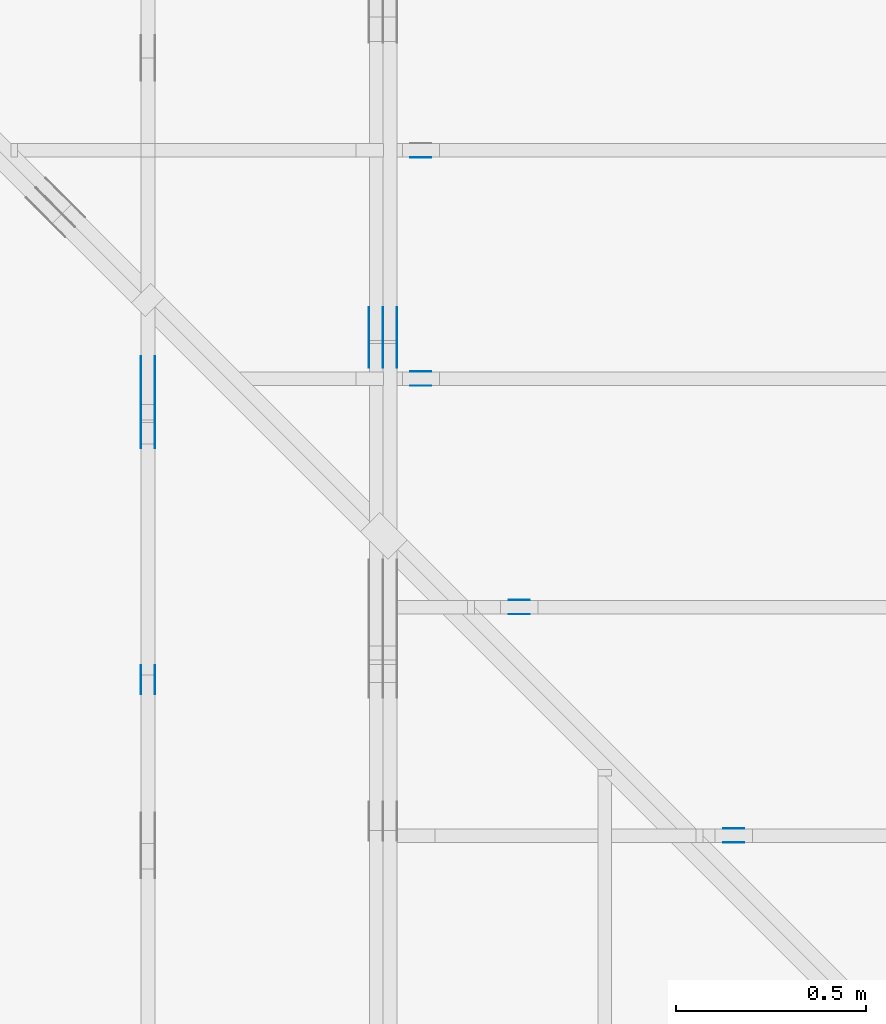
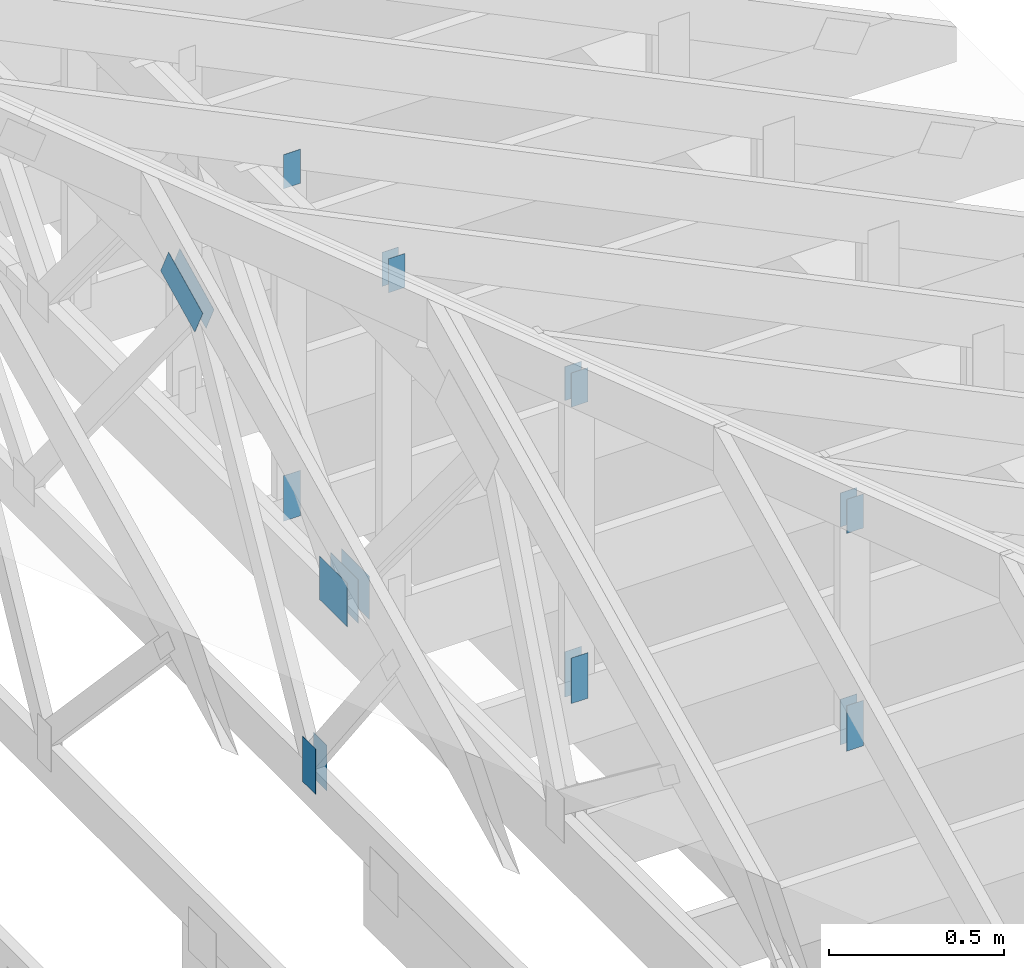
# One storey, part 116 of 159: 20 plates, 6 elements without a shape of their own.
"""IFC2X3 building model written with IfcOpenShell, lengths in millimetres."""

from ifc_helpers import new_model, si_unit, frame, origin, origin_with_axes, origin_2d, place, context, project, spatial, faceted_brep, element, aggregate, save


model = new_model("IFC2X3")

# Units and contexts
model_context = context("Model", 3, precision=1e-05, world=origin())
plan_context = context("Plan", 2, precision=1e-05, world=origin_2d())
ifc_project = project(units=[si_unit("LENGTHUNIT", "METRE", prefix="MILLI"), si_unit("AREAUNIT", "SQUARE_METRE"), si_unit("VOLUMEUNIT", "CUBIC_METRE"), si_unit("SOLIDANGLEUNIT", "STERADIAN"), si_unit("PLANEANGLEUNIT", "RADIAN"), si_unit("MASSUNIT", "GRAM"), si_unit("TIMEUNIT", "SECOND"), si_unit("THERMODYNAMICTEMPERATUREUNIT", "DEGREE_CELSIUS"), si_unit("LUMINOUSINTENSITYUNIT", "LUMEN")], contexts=[model_context, plan_context])

# Site, building, storey
site_placement = place(None, origin_with_axes())
site = spatial("IfcSite", under=ifc_project, at=site_placement, CompositionType="ELEMENT")
building_placement = place(site_placement, origin_with_axes())
building = spatial("IfcBuilding", under=site, at=building_placement, Name="Plan 1", CompositionType="ELEMENT")
storey_placement = place(building_placement, origin_with_axes())
storey = spatial("IfcBuildingStorey", under=building, at=storey_placement, Name="Etasje 1", CompositionType="ELEMENT", Elevation=0.0)

# Assembly, plates
assembly_1_placement = place(storey_placement, frame((18074.541652722903, -699.9989301294845, 4.408582873760558e-15), z_axis=(-1.0, 1.836909530733566e-16, 6.123031769111886e-17), x_axis=(-1.836909530733566e-16, -1.0, 0.0)))
assembly_1 = element("IfcElementAssembly", 1, at=assembly_1_placement, inside=storey, Name="V5 (30)", AssemblyPlace="FACTORY", PredefinedType="TRUSS")
plate_1_placement = place(assembly_1_placement, frame((-3428.636962890625, 299.0, 0.0), z_axis=(0.0, 0.0, 1.0), x_axis=(-1.0, 1.2246063538223773e-16, 0.0)))
plate_1 = element("IfcPlate", 2, at=plate_1_placement, Name="GNT100S 152x159", context=model_context, shape_type="Brep", body=[
    faceted_brep([(159.0, 152.00000000000003, 1.0), (0.0, 152.00000000000003, 1.0), (0.0, 0.0, 1.0), (159.0, 0.0, 1.0), (0.0, 152.00000000000003, 0.0), (159.0, 152.00000000000003, 1.9471241025775798e-14), (159.0, 5.684341886080802e-14, 1.9471241025775798e-14), (0.0, 5.684341886080802e-14, 0.0), (159.00003704238225, 6.529141447438163e-13, 5.2688872337669284e-30), (159.00003704238225, 6.529753750615074e-13, 1.0), (3.704238224599976e-05, 6.821822366001711e-13, 1.0), (3.704238224599976e-05, 6.8212100628248e-13, 1.227497416848817e-36), (159.00003704238225, 152.0000000000007, 0.0), (159.00003704238225, 152.0000000000007, 1.0), (159.00003704238225, 7.389644451905042e-13, 1.0), (159.00003704238225, 7.389644451905042e-13, 0.0), (3.704238224599976e-05, 152.0000000000007, 0.0), (3.704238224599976e-05, 152.0000000000007, 1.0), (159.00003704238225, 152.0000000000007, 1.0), (159.00003704238225, 152.0000000000007, 0.0), (3.704238224599976e-05, 6.821210263296962e-13, 0.0), (3.704238224606099e-05, 6.821210263296962e-13, 1.0), (3.704238226467501e-05, 152.0000000000007, 1.0), (3.704238226461378e-05, 152.0000000000007, -1.1397420192804459e-30)], [[[0, 1, 2, 3]], [[4, 5, 6, 7]], [[8, 9, 10, 11]], [[12, 13, 14, 15]], [[16, 17, 18, 19]], [[20, 21, 22, 23]]]),
])
plate_2_placement = place(assembly_1_placement, frame((-3428.636962890625, 299.0, -37.0), z_axis=(0.0, 0.0, 1.0), x_axis=(-1.0, 1.2246063538223773e-16, 0.0)))
plate_2 = element("IfcPlate", 3, at=plate_2_placement, Name="GNT100S 152x159", context=model_context, shape_type="Brep", body=[
    faceted_brep([(159.0, 152.00000000000003, 1.0), (0.0, 152.00000000000003, 1.0), (0.0, 0.0, 1.0), (159.0, 0.0, 1.0), (0.0, 152.00000000000003, 0.0), (159.0, 152.00000000000003, 1.9471241025775798e-14), (159.0, 5.684341886080802e-14, 1.9471241025775798e-14), (0.0, 5.684341886080802e-14, 0.0), (159.00003704238225, 6.529141447438163e-13, 5.2688872337669284e-30), (159.00003704238225, 6.529753750615074e-13, 1.0), (3.704238224599976e-05, 6.821822366001711e-13, 1.0), (3.704238224599976e-05, 6.8212100628248e-13, 1.227497416848817e-36), (159.00003704238225, 152.0000000000007, 0.0), (159.00003704238225, 152.0000000000007, 1.0), (159.00003704238225, 7.389644451905042e-13, 1.0), (159.00003704238225, 7.389644451905042e-13, 0.0), (3.704238224599976e-05, 152.0000000000007, 0.0), (3.704238224599976e-05, 152.0000000000007, 1.0), (159.00003704238225, 152.0000000000007, 1.0), (159.00003704238225, 152.0000000000007, 0.0), (3.704238224599976e-05, 6.821210263296962e-13, 0.0), (3.704238224606099e-05, 6.821210263296962e-13, 1.0), (3.704238226467501e-05, 152.0000000000007, 1.0), (3.704238226461378e-05, 152.0000000000007, -1.1397420192804459e-30)], [[[0, 1, 2, 3]], [[4, 5, 6, 7]], [[8, 9, 10, 11]], [[12, 13, 14, 15]], [[16, 17, 18, 19]], [[20, 21, 22, 23]]]),
])
plate_3_placement = place(assembly_1_placement, frame((-3428.636962890625, 299.0, -36.0), z_axis=(0.0, 0.0, 1.0), x_axis=(-1.0, 1.2246063538223773e-16, 0.0)))
plate_3 = element("IfcPlate", 4, at=plate_3_placement, Name="GNT100S 152x159", context=model_context, shape_type="Brep", body=[
    faceted_brep([(159.0, 152.00000000000003, 1.0), (0.0, 152.00000000000003, 1.0), (0.0, 0.0, 1.0), (159.0, 0.0, 1.0), (0.0, 152.00000000000003, 0.0), (159.0, 152.00000000000003, 1.9471241025775798e-14), (159.0, 5.684341886080802e-14, 1.9471241025775798e-14), (0.0, 5.684341886080802e-14, 0.0), (159.00003704238225, 6.529141447438163e-13, 5.2688872337669284e-30), (159.00003704238225, 6.529753750615074e-13, 1.0), (3.704238224599976e-05, 6.821822366001711e-13, 1.0), (3.704238224599976e-05, 6.8212100628248e-13, 1.227497416848817e-36), (159.00003704238225, 152.0000000000007, 0.0), (159.00003704238225, 152.0000000000007, 1.0), (159.00003704238225, 7.389644451905042e-13, 1.0), (159.00003704238225, 7.389644451905042e-13, 0.0), (3.704238224599976e-05, 152.0000000000007, 0.0), (3.704238224599976e-05, 152.0000000000007, 1.0), (159.00003704238225, 152.0000000000007, 1.0), (159.00003704238225, 152.0000000000007, 0.0), (3.704238224599976e-05, 6.821210263296962e-13, 0.0), (3.704238224606099e-05, 6.821210263296962e-13, 1.0), (3.704238226467501e-05, 152.0000000000007, 1.0), (3.704238226461378e-05, 152.0000000000007, -1.1397420192804459e-30)], [[[0, 1, 2, 3]], [[4, 5, 6, 7]], [[8, 9, 10, 11]], [[12, 13, 14, 15]], [[16, 17, 18, 19]], [[20, 21, 22, 23]]]),
])
plate_4_placement = place(assembly_1_placement, frame((-3428.636962890625, 299.0, -73.0), z_axis=(0.0, 0.0, 1.0), x_axis=(-1.0, 1.2246063538223773e-16, 0.0)))
plate_4 = element("IfcPlate", 5, at=plate_4_placement, Name="GNT100S 152x159", context=model_context, shape_type="Brep", body=[
    faceted_brep([(159.0, 152.00000000000003, 1.0), (0.0, 152.00000000000003, 1.0), (0.0, 0.0, 1.0), (159.0, 0.0, 1.0), (0.0, 152.00000000000003, 0.0), (159.0, 152.00000000000003, 1.9471241025775798e-14), (159.0, 5.684341886080802e-14, 1.9471241025775798e-14), (0.0, 5.684341886080802e-14, 0.0), (159.00003704238225, 6.529141447438163e-13, 5.2688872337669284e-30), (159.00003704238225, 6.529753750615074e-13, 1.0), (3.704238224599976e-05, 6.821822366001711e-13, 1.0), (3.704238224599976e-05, 6.8212100628248e-13, 1.227497416848817e-36), (159.00003704238225, 152.0000000000007, 0.0), (159.00003704238225, 152.0000000000007, 1.0), (159.00003704238225, 7.389644451905042e-13, 1.0), (159.00003704238225, 7.389644451905042e-13, 0.0), (3.704238224599976e-05, 152.0000000000007, 0.0), (3.704238224599976e-05, 152.0000000000007, 1.0), (159.00003704238225, 152.0000000000007, 1.0), (159.00003704238225, 152.0000000000007, 0.0), (3.704238224599976e-05, 6.821210263296962e-13, 0.0), (3.704238224606099e-05, 6.821210263296962e-13, 1.0), (3.704238226467501e-05, 152.0000000000007, 1.0), (3.704238226461378e-05, 152.0000000000007, -1.1397420192804459e-30)], [[[0, 1, 2, 3]], [[4, 5, 6, 7]], [[8, 9, 10, 11]], [[12, 13, 14, 15]], [[16, 17, 18, 19]], [[20, 21, 22, 23]]]),
])
aggregate(assembly_1, [plate_1, plate_2, plate_3, plate_4])

assembly_2_placement = place(storey_placement, frame((17475.02226140475, -699.9989301294827, 1.1021457184401395e-15), z_axis=(-1.0, 1.836909530733566e-16, 6.123031769111886e-17), x_axis=(-1.836909530733566e-16, -1.0, 0.0)))
assembly_2 = element("IfcElementAssembly", 6, at=assembly_2_placement, inside=storey, Name="V6 (31)", AssemblyPlace="FACTORY", PredefinedType="TRUSS")
plate_5_placement = place(assembly_2_placement, frame((-3217.9081733835806, 1580.4437865648827, 0.0), z_axis=(0.0, 0.0, 1.0), x_axis=(-0.898794046299167, 0.4383711467890773, 0.0)))
plate_5 = element("IfcPlate", 7, at=plate_5_placement, Name="GNT100S 103x218", context=model_context, shape_type="Brep", body=[
    faceted_brep([(218.00002818462735, 103.00013551740335, 1.0), (9.564507581671933e-05, 103.00013551740335, 1.0), (0.0, 6.784529296055553e-05, 1.0), (217.99993253955154, 6.784529296055553e-05, 1.0), (9.564507581671933e-05, 103.00013551740335, 1.1712756755697749e-20), (218.00002818462735, 103.00013551740335, 2.66964219648352e-14), (217.99993253955154, 0.0, 2.6696410252078444e-14), (0.0, 0.0, 0.0), (218.0000093475328, 8.409083143848917e-05, 2.4519450465496925e-30), (218.0000093475328, 8.40908314385504e-05, 1.0), (9.347532795800362e-06, 8.409083147859503e-05, 1.0), (9.347532795800362e-06, 8.40908314785338e-05, 0.0), (218.0000093475328, 103.00008409083148, -2.8398992587956425e-29), (218.0000093475328, 103.00008409083148, 1.0), (218.0000093475328, 8.40908314785338e-05, 1.0), (218.0000093475328, 8.40908314785338e-05, 0.0), (9.347533250547713e-06, 103.00008409083148, 0.0), (9.347533250547713e-06, 103.00008409083148, 1.0), (218.00000934753325, 103.00008409083146, 1.0), (218.00000934753325, 103.00008409083146, -7.888609052210118e-31), (9.347532795800375e-06, 8.40908314785338e-05, -7.52316384526264e-37), (9.347532795861606e-06, 8.40908314785338e-05, 1.0), (9.347533265886937e-06, 103.00008409083148, 1.0), (9.347533265825707e-06, 103.00008409083148, -9.35476365938057e-31)], [[[0, 1, 2, 3]], [[4, 5, 6, 7]], [[8, 9, 10, 11]], [[12, 13, 14, 15]], [[16, 17, 18, 19]], [[20, 21, 22, 23]]]),
])
plate_6_placement = place(assembly_2_placement, frame((-3217.9081733835806, 1580.4437865648827, -37.0), z_axis=(0.0, 0.0, 1.0), x_axis=(-0.898794046299167, 0.4383711467890773, 0.0)))
plate_6 = element("IfcPlate", 8, at=plate_6_placement, Name="GNT100S 103x218", context=model_context, shape_type="Brep", body=[
    faceted_brep([(218.00002818462735, 103.00013551740335, 1.0), (9.564507581671933e-05, 103.00013551740335, 1.0), (0.0, 6.784529296055553e-05, 1.0), (217.99993253955154, 6.784529296055553e-05, 1.0), (9.564507581671933e-05, 103.00013551740335, 1.1712756755697749e-20), (218.00002818462735, 103.00013551740335, 2.66964219648352e-14), (217.99993253955154, 0.0, 2.6696410252078444e-14), (0.0, 0.0, 0.0), (218.0000093475328, 8.409083143848917e-05, 2.4519450465496925e-30), (218.0000093475328, 8.40908314385504e-05, 1.0), (9.347532795800362e-06, 8.409083147859503e-05, 1.0), (9.347532795800362e-06, 8.40908314785338e-05, 0.0), (218.0000093475328, 103.00008409083148, -2.8398992587956425e-29), (218.0000093475328, 103.00008409083148, 1.0), (218.0000093475328, 8.40908314785338e-05, 1.0), (218.0000093475328, 8.40908314785338e-05, 0.0), (9.347533250547713e-06, 103.00008409083148, 0.0), (9.347533250547713e-06, 103.00008409083148, 1.0), (218.00000934753325, 103.00008409083146, 1.0), (218.00000934753325, 103.00008409083146, -7.888609052210118e-31), (9.347532795800375e-06, 8.40908314785338e-05, -7.52316384526264e-37), (9.347532795861606e-06, 8.40908314785338e-05, 1.0), (9.347533265886937e-06, 103.00008409083148, 1.0), (9.347533265825707e-06, 103.00008409083148, -9.35476365938057e-31)], [[[0, 1, 2, 3]], [[4, 5, 6, 7]], [[8, 9, 10, 11]], [[12, 13, 14, 15]], [[16, 17, 18, 19]], [[20, 21, 22, 23]]]),
])
plate_7_placement = place(assembly_2_placement, frame((-2571.392481149558, 291.4999999999981, 0.0), z_axis=(0.0, 0.0, 1.0), x_axis=(6.123031769111886e-17, 1.0, 0.0)))
plate_7 = element("IfcPlate", 9, at=plate_7_placement, Name="GNT100S 76x159", context=model_context, shape_type="Brep", body=[
    faceted_brep([(159.00000000000188, 76.00009697544192, 1.0), (1.8758328224066645e-12, 76.00009697544192, 1.0), (1.8758328224066645e-12, 9.697544192022178e-05, 1.0), (159.00000000000188, 9.697544192022178e-05, 1.0), (1.8758328224066645e-12, 76.00009697544192, 2.2971567930277643e-28), (159.00000000000188, 76.00009697544192, 1.947124102577603e-14), (159.00000000000188, 9.697544192022178e-05, 1.947124102577603e-14), (1.8758328224066645e-12, 9.697544192022178e-05, 2.2971567930277643e-28), (159.0, -2.92068615386637e-14, 1.788345410772899e-30), (159.0, -2.914563122097258e-14, 1.0), (1.1247455413666031e-32, 6.123031769111886e-17, 1.0), (0.0, 0.0, 0.0), (159.0, 76.0, 0.0), (159.0, 76.0, 1.0), (159.0, 0.0, 1.0), (159.0, 0.0, 0.0), (0.0, 76.0, 0.0), (-3.7491518045553436e-33, 76.0, 1.0), (159.0, 75.99999999999999, 1.0), (159.0, 75.99999999999999, -7.888609052210118e-31), (0.0, 0.0, 0.0), (6.123031769111886e-17, -7.498303609110687e-33, 1.0), (9.368238606741186e-15, 76.0, 1.0), (9.307008289050067e-15, 76.0, -5.698710742924122e-31)], [[[0, 1, 2, 3]], [[4, 5, 6, 7]], [[8, 9, 10, 11]], [[12, 13, 14, 15]], [[16, 17, 18, 19]], [[20, 21, 22, 23]]]),
])
plate_8_placement = place(assembly_2_placement, frame((-2571.392481149558, 291.4999999999981, -37.0), z_axis=(0.0, 0.0, 1.0), x_axis=(6.123031769111886e-17, 1.0, 0.0)))
plate_8 = element("IfcPlate", 10, at=plate_8_placement, Name="GNT100S 76x159", context=model_context, shape_type="Brep", body=[
    faceted_brep([(159.00000000000188, 76.00009697544192, 1.0), (1.8758328224066645e-12, 76.00009697544192, 1.0), (1.8758328224066645e-12, 9.697544192022178e-05, 1.0), (159.00000000000188, 9.697544192022178e-05, 1.0), (1.8758328224066645e-12, 76.00009697544192, 2.2971567930277643e-28), (159.00000000000188, 76.00009697544192, 1.947124102577603e-14), (159.00000000000188, 9.697544192022178e-05, 1.947124102577603e-14), (1.8758328224066645e-12, 9.697544192022178e-05, 2.2971567930277643e-28), (159.0, -2.92068615386637e-14, 1.788345410772899e-30), (159.0, -2.914563122097258e-14, 1.0), (1.1247455413666031e-32, 6.123031769111886e-17, 1.0), (0.0, 0.0, 0.0), (159.0, 76.0, 0.0), (159.0, 76.0, 1.0), (159.0, 0.0, 1.0), (159.0, 0.0, 0.0), (0.0, 76.0, 0.0), (-3.7491518045553436e-33, 76.0, 1.0), (159.0, 75.99999999999999, 1.0), (159.0, 75.99999999999999, -7.888609052210118e-31), (0.0, 0.0, 0.0), (6.123031769111886e-17, -7.498303609110687e-33, 1.0), (9.368238606741186e-15, 76.0, 1.0), (9.307008289050067e-15, 76.0, -5.698710742924122e-31)], [[[0, 1, 2, 3]], [[4, 5, 6, 7]], [[8, 9, 10, 11]], [[12, 13, 14, 15]], [[16, 17, 18, 19]], [[20, 21, 22, 23]]]),
])
aggregate(assembly_2, [plate_5, plate_6, plate_7, plate_8])

assembly_3_placement = place(storey_placement, frame((21100.012663101486, 3318.0074014212582, 1.1021457184401395e-15), z_axis=(1.2246063538223773e-16, 1.0, 6.123031769111886e-17), x_axis=(-1.0, 1.2246063538223773e-16, 0.0)))
assembly_3 = element("IfcElementAssembly", 11, at=assembly_3_placement, inside=storey, Name="S15 (41)", AssemblyPlace="FACTORY", PredefinedType="TRUSS")
plate_9_placement = place(assembly_3_placement, frame((2862.490401698563, 1424.37744140625, -37.0), z_axis=(0.0, 0.0, 1.0), x_axis=(6.123031769111886e-17, -1.0, 0.0)))
plate_9 = element("IfcPlate", 12, at=plate_9_placement, Name="GNT100S 55x119", context=model_context, shape_type="Brep", body=[
    faceted_brep([(119.0, 55.00007681706211, 1.0), (0.0, 55.00007681706211, 1.0), (0.0, 7.681706210860284e-05, 1.0), (119.0, 7.681706210860284e-05, 1.0), (0.0, 55.00007681706211, 0.0), (119.0, 55.00007681706211, 1.457281561048629e-14), (119.0, 7.681706210860284e-05, 1.457281561048629e-14), (0.0, 7.681706210860284e-05, 0.0), (119.00002904577786, -2.1859228751176052e-14, 1.3384475209173491e-30), (119.00002904577786, -2.1797998433484933e-14, 1.0), (2.904577786466689e-05, 6.122498224450015e-17, 1.0), (2.904577786466689e-05, -5.335446618717665e-21, 3.2669109148808856e-37), (119.00002904577786, 55.0, 0.0), (119.00002904577786, 55.0, 1.0), (119.00002904577786, 0.0, 1.0), (119.00002904577786, 0.0, 0.0), (2.904577786466689e-05, 55.0, 0.0), (2.904577786466689e-05, 55.0, 1.0), (119.00002904577786, 54.99999999999999, 1.0), (119.00002904577786, 54.99999999999999, -3.944304526105059e-31), (2.904577786466689e-05, 0.0, 0.0), (2.904577786472812e-05, -7.498303609110687e-33, 1.0), (2.9045777871463454e-05, 55.0, 1.0), (2.9045777871402223e-05, 55.0, -4.124066764605687e-31)], [[[0, 1, 2, 3]], [[4, 5, 6, 7]], [[8, 9, 10, 11]], [[12, 13, 14, 15]], [[16, 17, 18, 19]], [[20, 21, 22, 23]]]),
])
plate_10_placement = place(assembly_3_placement, frame((2917.490478515625, 143.5, -37.0), z_axis=(0.0, 0.0, 1.0), x_axis=(6.123031769111886e-17, 1.0, 0.0)))
plate_10 = element("IfcPlate", 13, at=plate_10_placement, Name="GNT100S 55x159", context=model_context, shape_type="Brep", body=[
    faceted_brep([(159.0, 55.0, 1.0), (0.0, 55.0, 1.0), (0.0, 0.0, 1.0), (159.0, 0.0, 1.0), (0.0, 55.0, 0.0), (159.0, 55.0, 1.9471241025775798e-14), (159.0, 0.0, 1.9471241025775798e-14), (0.0, 0.0, 0.0), (159.0, 7.681706480788008e-05, 1.788345571668688e-30), (159.0, 7.681706480794131e-05, 1.0), (1.1247455413666031e-32, 7.681706483714818e-05, 1.0), (0.0, 7.681706483708695e-05, 0.0), (159.0, 55.00007681706484, 0.0), (159.0, 55.00007681706484, 1.0), (159.0, 7.681706483708695e-05, 1.0), (159.0, 7.681706483708695e-05, 0.0), (-2.4308653429145085e-63, 55.00007681706484, 0.0), (-3.7491518045553436e-33, 55.00007681706484, 1.0), (159.0, 55.00007681706483, 1.0), (159.0, 55.00007681706483, -7.888609052210118e-31), (9.407066568148219e-21, 7.681706483708695e-05, -5.759976745092187e-37), (6.123972475768701e-17, 7.681706483708695e-05, 1.0), (6.796574670780762e-15, 55.00007681706484, 1.0), (6.7353443530896435e-15, 55.00007681706484, -4.124072744987623e-31)], [[[0, 1, 2, 3]], [[4, 5, 6, 7]], [[8, 9, 10, 11]], [[12, 13, 14, 15]], [[16, 17, 18, 19]], [[20, 21, 22, 23]]]),
])
aggregate(assembly_3, [plate_9, plate_10])

assembly_4_placement = place(storey_placement, frame((21100.012663101486, 1518.0074014212582, 1.1021457184401395e-15), z_axis=(1.2246063538223773e-16, 1.0, 6.123031769111886e-17), x_axis=(-1.0, 1.2246063538223773e-16, 0.0)))
assembly_4 = element("IfcElementAssembly", 14, at=assembly_4_placement, inside=storey, Name="S18 (40)", AssemblyPlace="FACTORY", PredefinedType="TRUSS")
plate_11_placement = place(assembly_4_placement, frame((2040.5946044921875, 1023.5120849609375, 0.0), z_axis=(0.0, 0.0, 1.0), x_axis=(6.123031769111886e-17, -1.0, 0.0)))
plate_11 = element("IfcPlate", 15, at=plate_11_placement, Name="GNT100S 55x119", context=model_context, shape_type="Brep", body=[
    faceted_brep([(119.0, 55.0001220703125, 1.0), (0.0, 55.0001220703125, 1.0), (0.0, 0.0, 1.0), (119.0, 0.0, 1.0), (0.0, 55.0001220703125, 0.0), (119.0, 55.0001220703125, 1.457281561048629e-14), (119.0, 0.0, 1.457281561048629e-14), (0.0, 0.0, 0.0), (119.0000183720665, 3.881499376435889e-05, 1.3384475843434453e-30), (119.0000183720665, 3.881499376442012e-05, 1.0), (1.837206650634471e-05, 3.881499378627934e-05, 1.0), (1.837206650634471e-05, 3.881499378621811e-05, 3.76158192263132e-37), (119.0000183720665, 55.000038814993786, 0.0), (119.0000183720665, 55.000038814993786, 1.0), (119.0000183720665, 3.881499378621811e-05, 1.0), (119.0000183720665, 3.881499378621811e-05, 0.0), (1.837206650634471e-05, 55.000038814993786, 0.0), (1.837206650634471e-05, 55.000038814993786, 1.0), (119.0000183720665, 55.00003881499378, 1.0), (119.0000183720665, 55.00003881499378, -3.944304526105059e-31), (1.8372066506344712e-05, 3.881499378621811e-05, -3.76158192263132e-37), (1.8372066506405942e-05, 3.881499378621811e-05, 1.0), (1.8372066513141277e-05, 55.000038814993786, 1.0), (1.8372066513080047e-05, 55.000038814993786, -4.12407052618761e-31)], [[[0, 1, 2, 3]], [[4, 5, 6, 7]], [[8, 9, 10, 11]], [[12, 13, 14, 15]], [[16, 17, 18, 19]], [[20, 21, 22, 23]]]),
])
plate_12_placement = place(assembly_4_placement, frame((2040.5946044921875, 1023.5120849609375, -37.0), z_axis=(0.0, 0.0, 1.0), x_axis=(6.123031769111886e-17, -1.0, 0.0)))
plate_12 = element("IfcPlate", 16, at=plate_12_placement, Name="GNT100S 55x119", context=model_context, shape_type="Brep", body=[
    faceted_brep([(119.0, 55.0001220703125, 1.0), (0.0, 55.0001220703125, 1.0), (0.0, 0.0, 1.0), (119.0, 0.0, 1.0), (0.0, 55.0001220703125, 0.0), (119.0, 55.0001220703125, 1.457281561048629e-14), (119.0, 0.0, 1.457281561048629e-14), (0.0, 0.0, 0.0), (119.0000183720665, 3.881499376435889e-05, 1.3384475843434453e-30), (119.0000183720665, 3.881499376442012e-05, 1.0), (1.837206650634471e-05, 3.881499378627934e-05, 1.0), (1.837206650634471e-05, 3.881499378621811e-05, 3.76158192263132e-37), (119.0000183720665, 55.000038814993786, 0.0), (119.0000183720665, 55.000038814993786, 1.0), (119.0000183720665, 3.881499378621811e-05, 1.0), (119.0000183720665, 3.881499378621811e-05, 0.0), (1.837206650634471e-05, 55.000038814993786, 0.0), (1.837206650634471e-05, 55.000038814993786, 1.0), (119.0000183720665, 55.00003881499378, 1.0), (119.0000183720665, 55.00003881499378, -3.944304526105059e-31), (1.8372066506344712e-05, 3.881499378621811e-05, -3.76158192263132e-37), (1.8372066506405942e-05, 3.881499378621811e-05, 1.0), (1.8372066513141277e-05, 55.000038814993786, 1.0), (1.8372066513080047e-05, 55.000038814993786, -4.12407052618761e-31)], [[[0, 1, 2, 3]], [[4, 5, 6, 7]], [[8, 9, 10, 11]], [[12, 13, 14, 15]], [[16, 17, 18, 19]], [[20, 21, 22, 23]]]),
])
plate_13_placement = place(assembly_4_placement, frame((2095.5947265625, 143.49999999999997, 0.0), z_axis=(0.0, 0.0, 1.0), x_axis=(6.123031769111886e-17, 1.0, 0.0)))
plate_13 = element("IfcPlate", 17, at=plate_13_placement, Name="GNT100S 55x159", context=model_context, shape_type="Brep", body=[
    faceted_brep([(159.0, 55.0001220703125, 1.0), (0.0, 55.0001220703125, 1.0), (2.842170943040401e-14, 0.0, 1.0), (159.0, 0.0, 1.0), (0.0, 55.0001220703125, 0.0), (159.0, 55.0001220703125, 1.9471241025775798e-14), (159.0, 0.0, 1.9471241025775798e-14), (2.842170943040401e-14, 0.0, 3.4805405954966126e-30), (159.0, 8.325534869790019e-05, 1.788345571668688e-30), (159.0, 8.325534869796142e-05, 1.0), (2.842170943040401e-14, 8.325534872716828e-05, 1.0), (2.842170943040401e-14, 8.325534872710705e-05, 0.0), (159.0, 55.00008325534873, 0.0), (159.0, 55.00008325534873, 1.0), (159.0, 8.325534872710705e-05, 1.0), (159.0, 8.325534872710705e-05, 0.0), (0.0, 55.00008325534873, 0.0), (-3.7491518045553436e-33, 55.00008325534873, 1.0), (159.0, 55.00008325534872, 1.0), (159.0, 55.00008325534872, -7.888609052210118e-31), (2.8421725676001787e-14, 8.325534872710705e-05, -9.947231130626802e-37), (2.8482955993692906e-14, 8.325534872710705e-05, 1.0), (1.0793384397962537e-14, 55.00008325534873, 1.0), (1.0732154080271418e-14, 55.00008325534873, -6.571332038450564e-31)], [[[0, 1, 2, 3]], [[4, 5, 6, 7]], [[8, 9, 10, 11]], [[12, 13, 14, 15]], [[16, 17, 18, 19]], [[20, 21, 22, 23]]]),
])
plate_14_placement = place(assembly_4_placement, frame((2095.5947265625, 143.49999999999997, -37.0), z_axis=(0.0, 0.0, 1.0), x_axis=(6.123031769111886e-17, 1.0, 0.0)))
plate_14 = element("IfcPlate", 18, at=plate_14_placement, Name="GNT100S 55x159", context=model_context, shape_type="Brep", body=[
    faceted_brep([(159.0, 55.0001220703125, 1.0), (0.0, 55.0001220703125, 1.0), (2.842170943040401e-14, 0.0, 1.0), (159.0, 0.0, 1.0), (0.0, 55.0001220703125, 0.0), (159.0, 55.0001220703125, 1.9471241025775798e-14), (159.0, 0.0, 1.9471241025775798e-14), (2.842170943040401e-14, 0.0, 3.4805405954966126e-30), (159.0, 8.325534869790019e-05, 1.788345571668688e-30), (159.0, 8.325534869796142e-05, 1.0), (2.842170943040401e-14, 8.325534872716828e-05, 1.0), (2.842170943040401e-14, 8.325534872710705e-05, 0.0), (159.0, 55.00008325534873, 0.0), (159.0, 55.00008325534873, 1.0), (159.0, 8.325534872710705e-05, 1.0), (159.0, 8.325534872710705e-05, 0.0), (0.0, 55.00008325534873, 0.0), (-3.7491518045553436e-33, 55.00008325534873, 1.0), (159.0, 55.00008325534872, 1.0), (159.0, 55.00008325534872, -7.888609052210118e-31), (2.8421725676001787e-14, 8.325534872710705e-05, -9.947231130626802e-37), (2.8482955993692906e-14, 8.325534872710705e-05, 1.0), (1.0793384397962537e-14, 55.00008325534873, 1.0), (1.0732154080271418e-14, 55.00008325534873, -6.571332038450564e-31)], [[[0, 1, 2, 3]], [[4, 5, 6, 7]], [[8, 9, 10, 11]], [[12, 13, 14, 15]], [[16, 17, 18, 19]], [[20, 21, 22, 23]]]),
])
aggregate(assembly_4, [plate_11, plate_12, plate_13, plate_14])

assembly_5_placement = place(storey_placement, frame((21100.012663101486, 2718.0074014212582, 1.1021457184401395e-15), z_axis=(1.2246063538223773e-16, 1.0, 6.123031769111886e-17), x_axis=(-1.0, 1.2246063538223773e-16, 0.0)))
assembly_5 = element("IfcElementAssembly", 19, at=assembly_5_placement, inside=storey, Name="S16 (39)", AssemblyPlace="FACTORY", PredefinedType="TRUSS")
plate_15_placement = place(assembly_5_placement, frame((2862.4904016985583, 1424.37744140625, 0.0), z_axis=(0.0, 0.0, 1.0), x_axis=(6.123031769111886e-17, -1.0, 0.0)))
plate_15 = element("IfcPlate", 20, at=plate_15_placement, Name="GNT100S 55x119", context=model_context, shape_type="Brep", body=[
    faceted_brep([(119.0, 55.000076817066656, 1.0), (0.0, 55.000076817066656, 1.0), (0.0, 7.681706665607635e-05, 1.0), (119.0, 7.681706665607635e-05, 1.0), (0.0, 55.000076817066656, 0.0), (119.0, 55.000076817066656, 1.457281561048629e-14), (119.0, 7.681706665607635e-05, 1.457281561048629e-14), (0.0, 7.681706665607635e-05, 0.0), (119.00002904680377, -2.1859228751364502e-14, 1.3384475209288881e-30), (119.00002904680377, -2.1797998433673383e-14, 1.0), (2.904680377469049e-05, 6.122498205604976e-17, 1.0), (2.904680377469049e-05, -5.3356350691076675e-21, 3.2670263036533743e-37), (119.00002904680377, 55.0, 0.0), (119.00002904680377, 55.0, 1.0), (119.00002904680377, 0.0, 1.0), (119.00002904680377, 0.0, 0.0), (2.904680377469049e-05, 55.0, 0.0), (2.904680377469049e-05, 55.0, 1.0), (119.00002904680377, 54.99999999999999, 1.0), (119.00002904680377, 54.99999999999999, -3.944304526105059e-31), (2.904680377469049e-05, 0.0, 0.0), (2.904680377475172e-05, -7.498303609110687e-33, 1.0), (2.9046803781487054e-05, 55.0, 1.0), (2.9046803781425823e-05, 55.0, -4.124066764605687e-31)], [[[0, 1, 2, 3]], [[4, 5, 6, 7]], [[8, 9, 10, 11]], [[12, 13, 14, 15]], [[16, 17, 18, 19]], [[20, 21, 22, 23]]]),
])
plate_16_placement = place(assembly_5_placement, frame((2862.4904016985583, 1424.37744140625, -37.0), z_axis=(0.0, 0.0, 1.0), x_axis=(6.123031769111886e-17, -1.0, 0.0)))
plate_16 = element("IfcPlate", 21, at=plate_16_placement, Name="GNT100S 55x119", context=model_context, shape_type="Brep", body=[
    faceted_brep([(119.0, 55.000076817066656, 1.0), (0.0, 55.000076817066656, 1.0), (0.0, 7.681706665607635e-05, 1.0), (119.0, 7.681706665607635e-05, 1.0), (0.0, 55.000076817066656, 0.0), (119.0, 55.000076817066656, 1.457281561048629e-14), (119.0, 7.681706665607635e-05, 1.457281561048629e-14), (0.0, 7.681706665607635e-05, 0.0), (119.00002904680377, -2.1859228751364502e-14, 1.3384475209288881e-30), (119.00002904680377, -2.1797998433673383e-14, 1.0), (2.904680377469049e-05, 6.122498205604976e-17, 1.0), (2.904680377469049e-05, -5.3356350691076675e-21, 3.2670263036533743e-37), (119.00002904680377, 55.0, 0.0), (119.00002904680377, 55.0, 1.0), (119.00002904680377, 0.0, 1.0), (119.00002904680377, 0.0, 0.0), (2.904680377469049e-05, 55.0, 0.0), (2.904680377469049e-05, 55.0, 1.0), (119.00002904680377, 54.99999999999999, 1.0), (119.00002904680377, 54.99999999999999, -3.944304526105059e-31), (2.904680377469049e-05, 0.0, 0.0), (2.904680377475172e-05, -7.498303609110687e-33, 1.0), (2.9046803781487054e-05, 55.0, 1.0), (2.9046803781425823e-05, 55.0, -4.124066764605687e-31)], [[[0, 1, 2, 3]], [[4, 5, 6, 7]], [[8, 9, 10, 11]], [[12, 13, 14, 15]], [[16, 17, 18, 19]], [[20, 21, 22, 23]]]),
])
aggregate(assembly_5, [plate_15, plate_16])

assembly_6_placement = place(storey_placement, frame((21100.012663101486, 2118.007401421258, 1.1021457184401395e-15), z_axis=(1.2246063538223773e-16, 1.0, 6.123031769111886e-17), x_axis=(-1.0, 1.2246063538223773e-16, 0.0)))
assembly_6 = element("IfcElementAssembly", 22, at=assembly_6_placement, inside=storey, Name="S17 (37)", AssemblyPlace="FACTORY", PredefinedType="TRUSS")
plate_17_placement = place(assembly_6_placement, frame((2604.594643307182, 1298.59326171875, 0.0), z_axis=(0.0, 0.0, 1.0), x_axis=(6.123031769111886e-17, -1.0, 0.0)))
plate_17 = element("IfcPlate", 23, at=plate_17_placement, Name="GNT100S 55x119", context=model_context, shape_type="Brep", body=[
    faceted_brep([(119.0, 55.000083255317804, 1.0), (0.0, 55.000083255317804, 1.0), (0.0, 8.325531780428719e-05, 1.0), (119.0, 8.325531780428719e-05, 1.0), (0.0, 55.000083255317804, 0.0), (119.0, 55.000083255317804, 1.457281561048629e-14), (119.0, 8.325531780428719e-05, 1.457281561048629e-14), (0.0, 8.325531780428719e-05, 0.0), (119.0000151774575, -2.1859226203691066e-14, 1.3384473649340342e-30), (119.0000151774575, -2.1797995885999947e-14, 1.0), (1.5177457498793956e-05, 6.122752972948568e-17, 1.0), (1.5177457498793956e-05, -2.7879616331838246e-21, 1.7070777651049617e-37), (119.0000151774575, 55.0, 0.0), (119.0000151774575, 55.0, 1.0), (119.0000151774575, 0.0, 1.0), (119.0000151774575, 0.0, 0.0), (1.5177457498793956e-05, 55.0, 0.0), (1.5177457498793956e-05, 55.0, 1.0), (119.0000151774575, 54.99999999999999, 1.0), (119.0000151774575, 54.99999999999999, -3.944304526105059e-31), (1.5177457498793956e-05, 0.0, 0.0), (1.5177457498855186e-05, -7.498303609110687e-33, 1.0), (1.5177457505590521e-05, 55.0, 1.0), (1.517745750552929e-05, 55.0, -4.124066764605687e-31)], [[[0, 1, 2, 3]], [[4, 5, 6, 7]], [[8, 9, 10, 11]], [[12, 13, 14, 15]], [[16, 17, 18, 19]], [[20, 21, 22, 23]]]),
])
plate_18_placement = place(assembly_6_placement, frame((2604.594643307182, 1298.59326171875, -37.0), z_axis=(0.0, 0.0, 1.0), x_axis=(6.123031769111886e-17, -1.0, 0.0)))
plate_18 = element("IfcPlate", 24, at=plate_18_placement, Name="GNT100S 55x119", context=model_context, shape_type="Brep", body=[
    faceted_brep([(119.0, 55.000083255317804, 1.0), (0.0, 55.000083255317804, 1.0), (0.0, 8.325531780428719e-05, 1.0), (119.0, 8.325531780428719e-05, 1.0), (0.0, 55.000083255317804, 0.0), (119.0, 55.000083255317804, 1.457281561048629e-14), (119.0, 8.325531780428719e-05, 1.457281561048629e-14), (0.0, 8.325531780428719e-05, 0.0), (119.0000151774575, -2.1859226203691066e-14, 1.3384473649340342e-30), (119.0000151774575, -2.1797995885999947e-14, 1.0), (1.5177457498793956e-05, 6.122752972948568e-17, 1.0), (1.5177457498793956e-05, -2.7879616331838246e-21, 1.7070777651049617e-37), (119.0000151774575, 55.0, 0.0), (119.0000151774575, 55.0, 1.0), (119.0000151774575, 0.0, 1.0), (119.0000151774575, 0.0, 0.0), (1.5177457498793956e-05, 55.0, 0.0), (1.5177457498793956e-05, 55.0, 1.0), (119.0000151774575, 54.99999999999999, 1.0), (119.0000151774575, 54.99999999999999, -3.944304526105059e-31), (1.5177457498793956e-05, 0.0, 0.0), (1.5177457498855186e-05, -7.498303609110687e-33, 1.0), (1.5177457505590521e-05, 55.0, 1.0), (1.517745750552929e-05, 55.0, -4.124066764605687e-31)], [[[0, 1, 2, 3]], [[4, 5, 6, 7]], [[8, 9, 10, 11]], [[12, 13, 14, 15]], [[16, 17, 18, 19]], [[20, 21, 22, 23]]]),
])
plate_19_placement = place(assembly_6_placement, frame((2659.5947265625, 143.5, 0.0), z_axis=(0.0, 0.0, 1.0), x_axis=(6.123031769111886e-17, 1.0, 0.0)))
plate_19 = element("IfcPlate", 25, at=plate_19_placement, Name="GNT100S 55x159", context=model_context, shape_type="Brep", body=[
    faceted_brep([(159.0, 55.0, 1.0), (0.0, 55.0, 1.0), (0.0, 0.0, 1.0), (159.0, 0.0, 1.0), (0.0, 55.0, 0.0), (159.0, 55.0, 1.9471241025775798e-14), (159.0, 0.0, 1.9471241025775798e-14), (0.0, 0.0, 0.0), (159.0, 8.325536324981541e-05, 1.788345571668688e-30), (159.0, 8.325536324987665e-05, 1.0), (1.1247455413666031e-32, 8.32553632790835e-05, 1.0), (0.0, 8.325536327902228e-05, 0.0), (159.0, 55.00008325536328, 0.0), (159.0, 55.00008325536328, 1.0), (159.0, 8.325536327902228e-05, 1.0), (159.0, 8.325536327902228e-05, 0.0), (0.0, 55.00008325536328, 0.0), (-3.7491518045553436e-33, 55.00008325536328, 1.0), (159.0, 55.00008325536327, 1.0), (159.0, 55.00008325536327, -7.888609052210118e-31), (1.0195504686128091e-20, 8.325536327902228e-05, -6.242739909529141e-37), (6.124051319580499e-17, 8.325536327902228e-05, 1.0), (6.79657545921888e-15, 55.00008325536328, 1.0), (6.735345141527761e-15, 55.00008325536328, -4.124073227750788e-31)], [[[0, 1, 2, 3]], [[4, 5, 6, 7]], [[8, 9, 10, 11]], [[12, 13, 14, 15]], [[16, 17, 18, 19]], [[20, 21, 22, 23]]]),
])
plate_20_placement = place(assembly_6_placement, frame((2659.5947265625, 143.5, -37.0), z_axis=(0.0, 0.0, 1.0), x_axis=(6.123031769111886e-17, 1.0, 0.0)))
plate_20 = element("IfcPlate", 26, at=plate_20_placement, Name="GNT100S 55x159", context=model_context, shape_type="Brep", body=[
    faceted_brep([(159.0, 55.0, 1.0), (0.0, 55.0, 1.0), (0.0, 0.0, 1.0), (159.0, 0.0, 1.0), (0.0, 55.0, 0.0), (159.0, 55.0, 1.9471241025775798e-14), (159.0, 0.0, 1.9471241025775798e-14), (0.0, 0.0, 0.0), (159.0, 8.325536324981541e-05, 1.788345571668688e-30), (159.0, 8.325536324987665e-05, 1.0), (1.1247455413666031e-32, 8.32553632790835e-05, 1.0), (0.0, 8.325536327902228e-05, 0.0), (159.0, 55.00008325536328, 0.0), (159.0, 55.00008325536328, 1.0), (159.0, 8.325536327902228e-05, 1.0), (159.0, 8.325536327902228e-05, 0.0), (0.0, 55.00008325536328, 0.0), (-3.7491518045553436e-33, 55.00008325536328, 1.0), (159.0, 55.00008325536327, 1.0), (159.0, 55.00008325536327, -7.888609052210118e-31), (1.0195504686128091e-20, 8.325536327902228e-05, -6.242739909529141e-37), (6.124051319580499e-17, 8.325536327902228e-05, 1.0), (6.79657545921888e-15, 55.00008325536328, 1.0), (6.735345141527761e-15, 55.00008325536328, -4.124073227750788e-31)], [[[0, 1, 2, 3]], [[4, 5, 6, 7]], [[8, 9, 10, 11]], [[12, 13, 14, 15]], [[16, 17, 18, 19]], [[20, 21, 22, 23]]]),
])
aggregate(assembly_6, [plate_17, plate_18, plate_19, plate_20])

save(model, "model.ifc")
